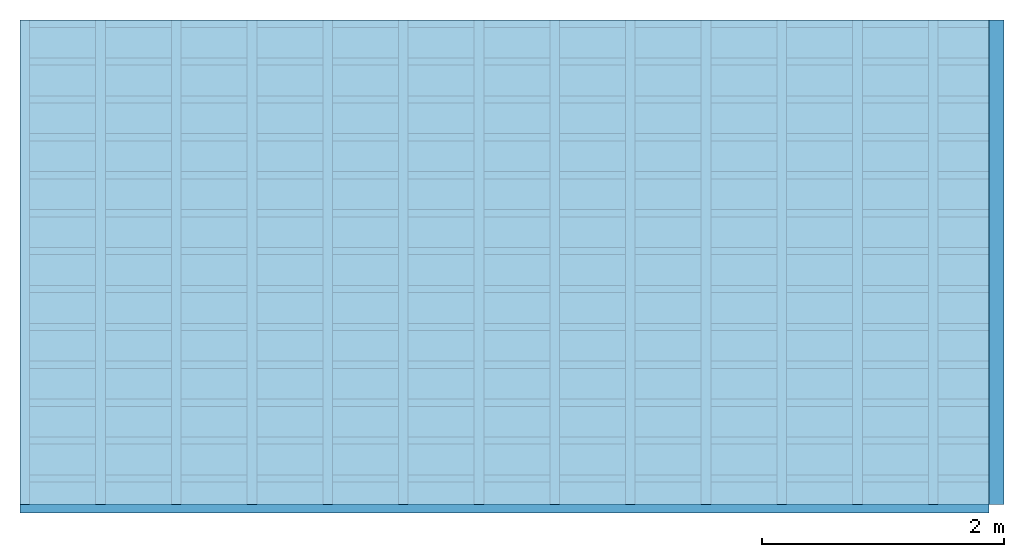
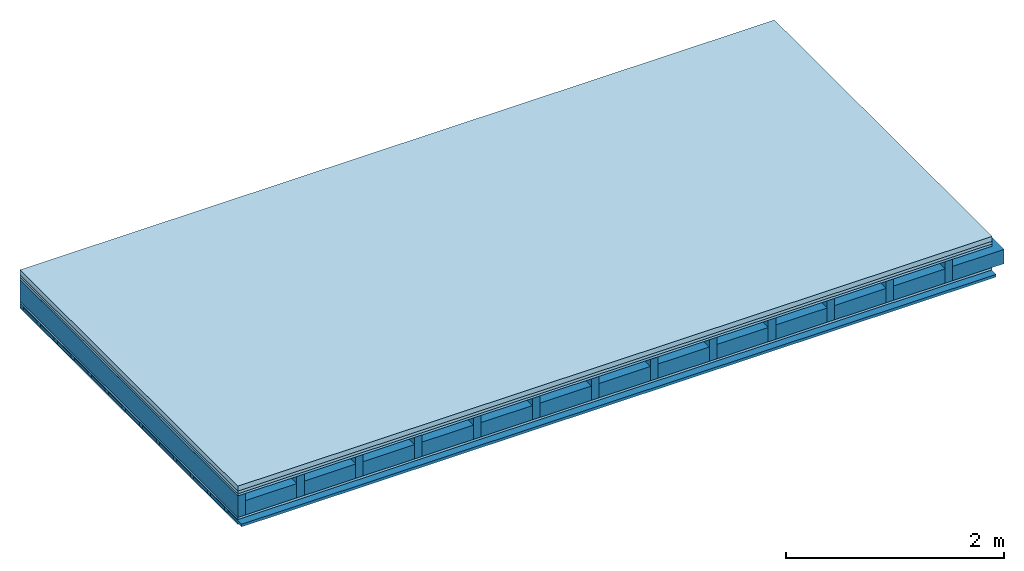
# One storey: 5 plates, 4 members, 1 element without a shape of its own.
"""IFC4 building model written with IfcOpenShell, lengths in metres."""

from ifc_helpers import new_model, si_unit, derived_unit, direction, frame, frame_2d, origin, origin_with_axes, place, context, project, spatial, rectangle, extrude, material, layer, layer_set, type_object, element, aggregate, save


model = new_model("IFC4")

# Units and contexts
plan_context = context("Plan", 3, precision=1e-05, world=origin(), true_north=direction((0.0, 1.0)))
model_context = context("Model", 3, precision=1e-05, world=origin(), true_north=direction((0.0, 1.0)))
ifc_project = project(units=[si_unit("LENGTHUNIT", "METRE"), derived_unit("SOUNDPRESSUREUNIT", [(si_unit("PRESSUREUNIT", "PASCAL", prefix="MICRO"), 0)]), si_unit("ENERGYUNIT", "JOULE", prefix="MEGA"), si_unit("MASSUNIT", "GRAM", prefix="KILO"), derived_unit("THERMALTRANSMITTANCEUNIT", [(si_unit("POWERUNIT", "WATT"), 1), (si_unit("AREAUNIT", "SQUARE_METRE"), -1), (si_unit("THERMODYNAMICTEMPERATUREUNIT", "KELVIN"), -1)]), derived_unit("AREADENSITYUNIT", [(si_unit("MASSUNIT", "GRAM", prefix="KILO"), 1), (si_unit("AREAUNIT", "SQUARE_METRE"), -1)]), derived_unit("USERDEFINED", [(si_unit("ENERGYUNIT", "JOULE", prefix="MEGA"), 1), (si_unit("AREAUNIT", "SQUARE_METRE"), -1)])], contexts=[plan_context, model_context])

# Site, building, storey
site = spatial("IfcSite", under=ifc_project)
building_placement = place(None, origin())
building = spatial("IfcBuilding", under=site, at=building_placement)
storey_placement = place(building_placement, origin())
storey = spatial("IfcBuildingStorey", under=building, at=storey_placement)

# Slab, members, plates
ifc_material_1 = material(Category="04.005")
ifc_layer_1 = layer(ifc_material_1, 0.055, Name="On-material")
ifc_material_2 = material()
ifc_layer_2 = layer(ifc_material_2, 0.03, Name="Impact sound insulation")
ifc_material_3 = material(Category="07.001")
ifc_layer_3 = layer(ifc_material_3, 0.025, Name="Sub-floor")
ifc_material_4 = material(Name="Rigid, of the art")
ifc_layer_4 = layer(ifc_material_4, 0.0, Name="Bond")
ifc_layer_5 = layer(None, 0.24, Name="Supporting structure")
ifc_layer_6 = layer(ifc_material_4, 0.0, Name="Bond")
ifc_layer_7 = layer(ifc_material_3, 0.025, Name="Lower layer 1")
ifc_layer_8 = layer(None, 0.04, Name="Battens / profiles")
ifc_material_5 = material(Category="03.007")
ifc_layer_9 = layer(ifc_material_5, 0.015, Name="Ceiling covering 1st layer")
ifc_material_6 = material(Name="Glued joints")
ifc_layer_10 = layer(ifc_material_6, 0.0, Name="Surface / treatment")
ifc_layer_set = layer_set([ifc_layer_1, ifc_layer_2, ifc_layer_3, ifc_layer_4, ifc_layer_5, ifc_layer_6, ifc_layer_7, ifc_layer_8, ifc_layer_9, ifc_layer_10])
slab_type = type_object("IfcSlabType", Name="A0710", PredefinedType="NOTDEFINED", material=ifc_layer_set)
slab_placement = place(None, frame((0.0, 0.0, 0.0), z_axis=(0.0, 0.0, -1.0), x_axis=(1.0, 0.0, 0.0)))
slab = element("IfcSlab", 1, at=slab_placement, inside=storey, type_object=slab_type, material=ifc_layer_set, Name="Slab #1")
ifc_material_7 = material()
member_1_placement = place(slab_placement, origin())
member_1 = element("IfcMember", 2, at=member_1_placement, material=ifc_material_7, Name="Supporting structure", context=plan_context, shape_type="SweptSolid", body=[
    extrude(rectangle(XDim=0.08, YDim=0.24, at=frame_2d((0.04, 0.12), x_axis=(1.0, 0.0))), frame((0.0, 4.0, 0.11), z_axis=(0.0, -1.0, 0.0), x_axis=(1.0, 0.0, 0.0)), (0.0, 0.0, 1.0), 4.0),
    extrude(rectangle(XDim=0.08, YDim=0.24, at=frame_2d((0.04, 0.12), x_axis=(1.0, 0.0))), frame((0.625, 4.0, 0.11), z_axis=(0.0, -1.0, 0.0), x_axis=(1.0, 0.0, 0.0)), (0.0, 0.0, 1.0), 4.0),
    extrude(rectangle(XDim=0.08, YDim=0.24, at=frame_2d((0.04, 0.12), x_axis=(1.0, 0.0))), frame((1.25, 4.0, 0.11), z_axis=(0.0, -1.0, 0.0), x_axis=(1.0, 0.0, 0.0)), (0.0, 0.0, 1.0), 4.0),
    extrude(rectangle(XDim=0.08, YDim=0.24, at=frame_2d((0.04, 0.12), x_axis=(1.0, 0.0))), frame((1.875, 4.0, 0.11), z_axis=(0.0, -1.0, 0.0), x_axis=(1.0, 0.0, 0.0)), (0.0, 0.0, 1.0), 4.0),
    extrude(rectangle(XDim=0.08, YDim=0.24, at=frame_2d((0.04, 0.12), x_axis=(1.0, 0.0))), frame((2.5, 4.0, 0.11), z_axis=(0.0, -1.0, 0.0), x_axis=(1.0, 0.0, 0.0)), (0.0, 0.0, 1.0), 4.0),
    extrude(rectangle(XDim=0.08, YDim=0.24, at=frame_2d((0.04, 0.12), x_axis=(1.0, 0.0))), frame((3.125, 4.0, 0.11), z_axis=(0.0, -1.0, 0.0), x_axis=(1.0, 0.0, 0.0)), (0.0, 0.0, 1.0), 4.0),
    extrude(rectangle(XDim=0.08, YDim=0.24, at=frame_2d((0.04, 0.12), x_axis=(1.0, 0.0))), frame((3.75, 4.0, 0.11), z_axis=(0.0, -1.0, 0.0), x_axis=(1.0, 0.0, 0.0)), (0.0, 0.0, 1.0), 4.0),
    extrude(rectangle(XDim=0.08, YDim=0.24, at=frame_2d((0.04, 0.12), x_axis=(1.0, 0.0))), frame((4.375, 4.0, 0.11), z_axis=(0.0, -1.0, 0.0), x_axis=(1.0, 0.0, 0.0)), (0.0, 0.0, 1.0), 4.0),
    extrude(rectangle(XDim=0.08, YDim=0.24, at=frame_2d((0.04, 0.12), x_axis=(1.0, 0.0))), frame((5.0, 4.0, 0.11), z_axis=(0.0, -1.0, 0.0), x_axis=(1.0, 0.0, 0.0)), (0.0, 0.0, 1.0), 4.0),
    extrude(rectangle(XDim=0.08, YDim=0.24, at=frame_2d((0.04, 0.12), x_axis=(1.0, 0.0))), frame((5.625, 4.0, 0.11), z_axis=(0.0, -1.0, 0.0), x_axis=(1.0, 0.0, 0.0)), (0.0, 0.0, 1.0), 4.0),
    extrude(rectangle(XDim=0.08, YDim=0.24, at=frame_2d((0.04, 0.12), x_axis=(1.0, 0.0))), frame((6.25, 4.0, 0.11), z_axis=(0.0, -1.0, 0.0), x_axis=(1.0, 0.0, 0.0)), (0.0, 0.0, 1.0), 4.0),
    extrude(rectangle(XDim=0.08, YDim=0.24, at=frame_2d((0.04, 0.12), x_axis=(1.0, 0.0))), frame((6.875, 4.0, 0.11), z_axis=(0.0, -1.0, 0.0), x_axis=(1.0, 0.0, 0.0)), (0.0, 0.0, 1.0), 4.0),
    extrude(rectangle(XDim=0.08, YDim=0.24, at=frame_2d((0.04, 0.12), x_axis=(1.0, 0.0))), frame((7.5, 4.0, 0.11), z_axis=(0.0, -1.0, 0.0), x_axis=(1.0, 0.0, 0.0)), (0.0, 0.0, 1.0), 4.0),
])
ifc_material_8 = material()
member_2_placement = place(slab_placement, origin())
member_2 = element("IfcMember", 3, at=member_2_placement, material=ifc_material_8, Name="in supporting structure", context=plan_context, shape_type="SweptSolid", body=[
    extrude(rectangle(XDim=0.545, YDim=0.16, at=frame_2d((0.2725, 0.08), x_axis=(1.0, 0.0))), frame((0.08, 4.0, 0.19), z_axis=(0.0, -1.0, 0.0), x_axis=(1.0, 0.0, 0.0)), (0.0, 0.0, 1.0), 4.0),
    extrude(rectangle(XDim=0.545, YDim=0.16, at=frame_2d((0.2725, 0.08), x_axis=(1.0, 0.0))), frame((0.705, 4.0, 0.19), z_axis=(0.0, -1.0, 0.0), x_axis=(1.0, 0.0, 0.0)), (0.0, 0.0, 1.0), 4.0),
    extrude(rectangle(XDim=0.545, YDim=0.16, at=frame_2d((0.2725, 0.08), x_axis=(1.0, 0.0))), frame((1.33, 4.0, 0.19), z_axis=(0.0, -1.0, 0.0), x_axis=(1.0, 0.0, 0.0)), (0.0, 0.0, 1.0), 4.0),
    extrude(rectangle(XDim=0.545, YDim=0.16, at=frame_2d((0.2725, 0.08), x_axis=(1.0, 0.0))), frame((1.955, 4.0, 0.19), z_axis=(0.0, -1.0, 0.0), x_axis=(1.0, 0.0, 0.0)), (0.0, 0.0, 1.0), 4.0),
    extrude(rectangle(XDim=0.545, YDim=0.16, at=frame_2d((0.2725, 0.08), x_axis=(1.0, 0.0))), frame((2.58, 4.0, 0.19), z_axis=(0.0, -1.0, 0.0), x_axis=(1.0, 0.0, 0.0)), (0.0, 0.0, 1.0), 4.0),
    extrude(rectangle(XDim=0.545, YDim=0.16, at=frame_2d((0.2725, 0.08), x_axis=(1.0, 0.0))), frame((3.205, 4.0, 0.19), z_axis=(0.0, -1.0, 0.0), x_axis=(1.0, 0.0, 0.0)), (0.0, 0.0, 1.0), 4.0),
    extrude(rectangle(XDim=0.545, YDim=0.16, at=frame_2d((0.2725, 0.08), x_axis=(1.0, 0.0))), frame((3.83, 4.0, 0.19), z_axis=(0.0, -1.0, 0.0), x_axis=(1.0, 0.0, 0.0)), (0.0, 0.0, 1.0), 4.0),
    extrude(rectangle(XDim=0.545, YDim=0.16, at=frame_2d((0.2725, 0.08), x_axis=(1.0, 0.0))), frame((4.455, 4.0, 0.19), z_axis=(0.0, -1.0, 0.0), x_axis=(1.0, 0.0, 0.0)), (0.0, 0.0, 1.0), 4.0),
    extrude(rectangle(XDim=0.545, YDim=0.16, at=frame_2d((0.2725, 0.08), x_axis=(1.0, 0.0))), frame((5.08, 4.0, 0.19), z_axis=(0.0, -1.0, 0.0), x_axis=(1.0, 0.0, 0.0)), (0.0, 0.0, 1.0), 4.0),
    extrude(rectangle(XDim=0.545, YDim=0.16, at=frame_2d((0.2725, 0.08), x_axis=(1.0, 0.0))), frame((5.705, 4.0, 0.19), z_axis=(0.0, -1.0, 0.0), x_axis=(1.0, 0.0, 0.0)), (0.0, 0.0, 1.0), 4.0),
    extrude(rectangle(XDim=0.545, YDim=0.16, at=frame_2d((0.2725, 0.08), x_axis=(1.0, 0.0))), frame((6.33, 4.0, 0.19), z_axis=(0.0, -1.0, 0.0), x_axis=(1.0, 0.0, 0.0)), (0.0, 0.0, 1.0), 4.0),
    extrude(rectangle(XDim=0.545, YDim=0.16, at=frame_2d((0.2725, 0.08), x_axis=(1.0, 0.0))), frame((6.955, 4.0, 0.19), z_axis=(0.0, -1.0, 0.0), x_axis=(1.0, 0.0, 0.0)), (0.0, 0.0, 1.0), 4.0),
    extrude(rectangle(XDim=0.545, YDim=0.16, at=frame_2d((0.2725, 0.08), x_axis=(1.0, 0.0))), frame((7.58, 4.0, 0.19), z_axis=(0.0, -1.0, 0.0), x_axis=(1.0, 0.0, 0.0)), (0.0, 0.0, 1.0), 4.0),
])
ifc_material_9 = material()
member_3_placement = place(slab_placement, origin())
member_3 = element("IfcMember", 4, at=member_3_placement, material=ifc_material_9, Name="Battens / profiles", context=plan_context, shape_type="SweptSolid", body=[
    extrude(rectangle(XDim=0.06, YDim=0.04, at=frame_2d((0.03, 0.02), x_axis=(1.0, 0.0))), frame((0.0, 0.0, 0.375), z_axis=(1.0, 0.0, 0.0), x_axis=(0.0, 1.0, 0.0)), (0.0, 0.0, 1.0), 8.0),
    extrude(rectangle(XDim=0.06, YDim=0.04, at=frame_2d((0.03, 0.02), x_axis=(1.0, 0.0))), frame((0.0, 0.313, 0.375), z_axis=(1.0, 0.0, 0.0), x_axis=(0.0, 1.0, 0.0)), (0.0, 0.0, 1.0), 8.0),
    extrude(rectangle(XDim=0.06, YDim=0.04, at=frame_2d((0.03, 0.02), x_axis=(1.0, 0.0))), frame((0.0, 0.626, 0.375), z_axis=(1.0, 0.0, 0.0), x_axis=(0.0, 1.0, 0.0)), (0.0, 0.0, 1.0), 8.0),
    extrude(rectangle(XDim=0.06, YDim=0.04, at=frame_2d((0.03, 0.02), x_axis=(1.0, 0.0))), frame((0.0, 0.939, 0.375), z_axis=(1.0, 0.0, 0.0), x_axis=(0.0, 1.0, 0.0)), (0.0, 0.0, 1.0), 8.0),
    extrude(rectangle(XDim=0.06, YDim=0.04, at=frame_2d((0.03, 0.02), x_axis=(1.0, 0.0))), frame((0.0, 1.252, 0.375), z_axis=(1.0, 0.0, 0.0), x_axis=(0.0, 1.0, 0.0)), (0.0, 0.0, 1.0), 8.0),
    extrude(rectangle(XDim=0.06, YDim=0.04, at=frame_2d((0.03, 0.02), x_axis=(1.0, 0.0))), frame((0.0, 1.565, 0.375), z_axis=(1.0, 0.0, 0.0), x_axis=(0.0, 1.0, 0.0)), (0.0, 0.0, 1.0), 8.0),
    extrude(rectangle(XDim=0.06, YDim=0.04, at=frame_2d((0.03, 0.02), x_axis=(1.0, 0.0))), frame((0.0, 1.878, 0.375), z_axis=(1.0, 0.0, 0.0), x_axis=(0.0, 1.0, 0.0)), (0.0, 0.0, 1.0), 8.0),
    extrude(rectangle(XDim=0.06, YDim=0.04, at=frame_2d((0.03, 0.02), x_axis=(1.0, 0.0))), frame((0.0, 2.191, 0.375), z_axis=(1.0, 0.0, 0.0), x_axis=(0.0, 1.0, 0.0)), (0.0, 0.0, 1.0), 8.0),
    extrude(rectangle(XDim=0.06, YDim=0.04, at=frame_2d((0.03, 0.02), x_axis=(1.0, 0.0))), frame((0.0, 2.504, 0.375), z_axis=(1.0, 0.0, 0.0), x_axis=(0.0, 1.0, 0.0)), (0.0, 0.0, 1.0), 8.0),
    extrude(rectangle(XDim=0.06, YDim=0.04, at=frame_2d((0.03, 0.02), x_axis=(1.0, 0.0))), frame((0.0, 2.817, 0.375), z_axis=(1.0, 0.0, 0.0), x_axis=(0.0, 1.0, 0.0)), (0.0, 0.0, 1.0), 8.0),
    extrude(rectangle(XDim=0.06, YDim=0.04, at=frame_2d((0.03, 0.02), x_axis=(1.0, 0.0))), frame((0.0, 3.13, 0.375), z_axis=(1.0, 0.0, 0.0), x_axis=(0.0, 1.0, 0.0)), (0.0, 0.0, 1.0), 8.0),
    extrude(rectangle(XDim=0.06, YDim=0.04, at=frame_2d((0.03, 0.02), x_axis=(1.0, 0.0))), frame((0.0, 3.443, 0.375), z_axis=(1.0, 0.0, 0.0), x_axis=(0.0, 1.0, 0.0)), (0.0, 0.0, 1.0), 8.0),
    extrude(rectangle(XDim=0.06, YDim=0.04, at=frame_2d((0.03, 0.02), x_axis=(1.0, 0.0))), frame((0.0, 3.756, 0.375), z_axis=(1.0, 0.0, 0.0), x_axis=(0.0, 1.0, 0.0)), (0.0, 0.0, 1.0), 8.0),
])
ifc_material_10 = material()
member_4_placement = place(slab_placement, origin())
member_4 = element("IfcMember", 5, at=member_4_placement, material=ifc_material_10, Name="Cavity", context=plan_context, shape_type="SweptSolid", body=[
    extrude(rectangle(XDim=0.253, YDim=0.03, at=frame_2d((0.1265, 0.015), x_axis=(1.0, 0.0))), frame((0.0, 0.06, 0.385), z_axis=(1.0, 0.0, 0.0), x_axis=(0.0, 1.0, 0.0)), (0.0, 0.0, 1.0), 8.0),
    extrude(rectangle(XDim=0.253, YDim=0.03, at=frame_2d((0.1265, 0.015), x_axis=(1.0, 0.0))), frame((0.0, 0.373, 0.385), z_axis=(1.0, 0.0, 0.0), x_axis=(0.0, 1.0, 0.0)), (0.0, 0.0, 1.0), 8.0),
    extrude(rectangle(XDim=0.253, YDim=0.03, at=frame_2d((0.1265, 0.015), x_axis=(1.0, 0.0))), frame((0.0, 0.686, 0.385), z_axis=(1.0, 0.0, 0.0), x_axis=(0.0, 1.0, 0.0)), (0.0, 0.0, 1.0), 8.0),
    extrude(rectangle(XDim=0.253, YDim=0.03, at=frame_2d((0.1265, 0.015), x_axis=(1.0, 0.0))), frame((0.0, 0.999, 0.385), z_axis=(1.0, 0.0, 0.0), x_axis=(0.0, 1.0, 0.0)), (0.0, 0.0, 1.0), 8.0),
    extrude(rectangle(XDim=0.253, YDim=0.03, at=frame_2d((0.1265, 0.015), x_axis=(1.0, 0.0))), frame((0.0, 1.312, 0.385), z_axis=(1.0, 0.0, 0.0), x_axis=(0.0, 1.0, 0.0)), (0.0, 0.0, 1.0), 8.0),
    extrude(rectangle(XDim=0.253, YDim=0.03, at=frame_2d((0.1265, 0.015), x_axis=(1.0, 0.0))), frame((0.0, 1.625, 0.385), z_axis=(1.0, 0.0, 0.0), x_axis=(0.0, 1.0, 0.0)), (0.0, 0.0, 1.0), 8.0),
    extrude(rectangle(XDim=0.253, YDim=0.03, at=frame_2d((0.1265, 0.015), x_axis=(1.0, 0.0))), frame((0.0, 1.938, 0.385), z_axis=(1.0, 0.0, 0.0), x_axis=(0.0, 1.0, 0.0)), (0.0, 0.0, 1.0), 8.0),
    extrude(rectangle(XDim=0.253, YDim=0.03, at=frame_2d((0.1265, 0.015), x_axis=(1.0, 0.0))), frame((0.0, 2.251, 0.385), z_axis=(1.0, 0.0, 0.0), x_axis=(0.0, 1.0, 0.0)), (0.0, 0.0, 1.0), 8.0),
    extrude(rectangle(XDim=0.253, YDim=0.03, at=frame_2d((0.1265, 0.015), x_axis=(1.0, 0.0))), frame((0.0, 2.564, 0.385), z_axis=(1.0, 0.0, 0.0), x_axis=(0.0, 1.0, 0.0)), (0.0, 0.0, 1.0), 8.0),
    extrude(rectangle(XDim=0.253, YDim=0.03, at=frame_2d((0.1265, 0.015), x_axis=(1.0, 0.0))), frame((0.0, 2.877, 0.385), z_axis=(1.0, 0.0, 0.0), x_axis=(0.0, 1.0, 0.0)), (0.0, 0.0, 1.0), 8.0),
    extrude(rectangle(XDim=0.253, YDim=0.03, at=frame_2d((0.1265, 0.015), x_axis=(1.0, 0.0))), frame((0.0, 3.19, 0.385), z_axis=(1.0, 0.0, 0.0), x_axis=(0.0, 1.0, 0.0)), (0.0, 0.0, 1.0), 8.0),
    extrude(rectangle(XDim=0.253, YDim=0.03, at=frame_2d((0.1265, 0.015), x_axis=(1.0, 0.0))), frame((0.0, 3.503, 0.385), z_axis=(1.0, 0.0, 0.0), x_axis=(0.0, 1.0, 0.0)), (0.0, 0.0, 1.0), 8.0),
    extrude(rectangle(XDim=0.253, YDim=0.03, at=frame_2d((0.1265, 0.015), x_axis=(1.0, 0.0))), frame((0.0, 3.816, 0.385), z_axis=(1.0, 0.0, 0.0), x_axis=(0.0, 1.0, 0.0)), (0.0, 0.0, 1.0), 8.0),
])
plate_1_placement = place(slab_placement, origin())
plate_1 = element("IfcPlate", 6, at=plate_1_placement, material=ifc_material_1, Name="On-material", context=plan_context, shape_type="SweptSolid", body=[
    extrude(rectangle(XDim=8.0, YDim=4.0, at=frame_2d((4.0, 2.0), x_axis=(1.0, 0.0))), origin_with_axes(), (0.0, 0.0, 1.0), 0.055),
])
plate_2_placement = place(slab_placement, origin())
plate_2 = element("IfcPlate", 7, at=plate_2_placement, material=ifc_material_2, Name="Impact sound insulation", context=plan_context, shape_type="SweptSolid", body=[
    extrude(rectangle(XDim=8.0, YDim=4.0, at=frame_2d((4.0, 2.0), x_axis=(1.0, 0.0))), frame((0.0, 0.0, 0.055), z_axis=(0.0, 0.0, 1.0), x_axis=(1.0, 0.0, 0.0)), (0.0, 0.0, 1.0), 0.03),
])
plate_3_placement = place(slab_placement, origin())
plate_3 = element("IfcPlate", 8, at=plate_3_placement, material=ifc_material_3, Name="Sub-floor", context=plan_context, shape_type="SweptSolid", body=[
    extrude(rectangle(XDim=8.0, YDim=4.0, at=frame_2d((4.0, 2.0), x_axis=(1.0, 0.0))), frame((0.0, 0.0, 0.085), z_axis=(0.0, 0.0, 1.0), x_axis=(1.0, 0.0, 0.0)), (0.0, 0.0, 1.0), 0.025),
])
plate_4_placement = place(slab_placement, origin())
plate_4 = element("IfcPlate", 9, at=plate_4_placement, material=ifc_material_3, Name="Lower layer 1", context=plan_context, shape_type="SweptSolid", body=[
    extrude(rectangle(XDim=8.0, YDim=4.0, at=frame_2d((4.0, 2.0), x_axis=(1.0, 0.0))), frame((0.0, 0.0, 0.35), z_axis=(0.0, 0.0, 1.0), x_axis=(1.0, 0.0, 0.0)), (0.0, 0.0, 1.0), 0.025),
])
plate_5_placement = place(slab_placement, origin())
plate_5 = element("IfcPlate", 10, at=plate_5_placement, material=ifc_material_5, Name="Ceiling covering 1st layer", context=plan_context, shape_type="SweptSolid", body=[
    extrude(rectangle(XDim=8.0, YDim=4.0, at=frame_2d((4.0, 2.0), x_axis=(1.0, 0.0))), frame((0.0, 0.0, 0.415), z_axis=(0.0, 0.0, 1.0), x_axis=(1.0, 0.0, 0.0)), (0.0, 0.0, 1.0), 0.015),
])
aggregate(slab, [plate_1, plate_2, plate_3, member_1, member_2, plate_4, member_3, member_4, plate_5])

save(model, "model.ifc")
